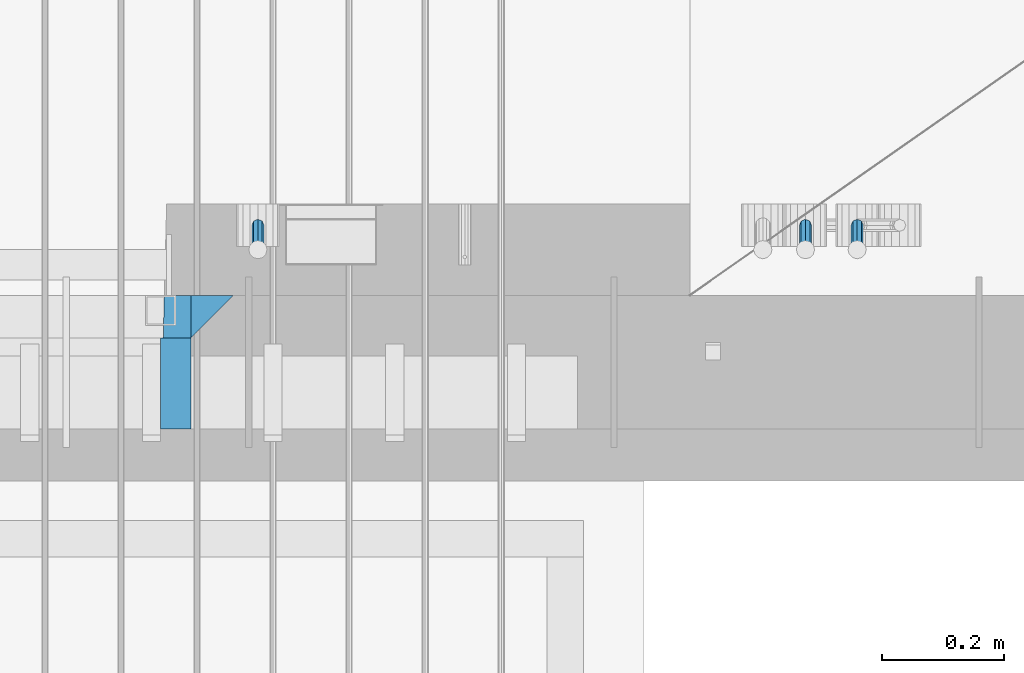
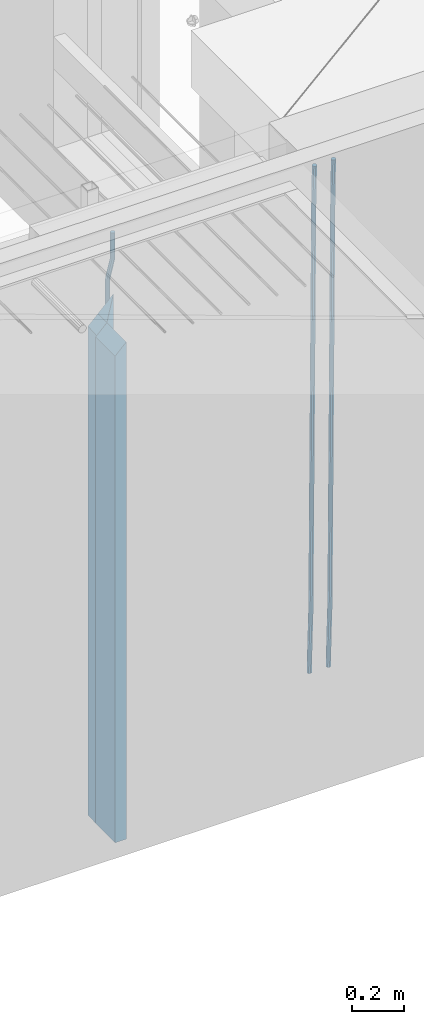
# One storey, part 130 of 350: 6 beams, 1 element without a shape of its own.
"""IFC2X3 building model written with IfcOpenShell, lengths in millimetres."""

from ifc_helpers import new_model, si_unit, frame, origin_with_axes, place, context, subcontext, project, spatial, faceted_brep, material, type_object, element, aggregate, save


model = new_model("IFC2X3")

# Units and contexts
model_context = context("Model", 3, precision=1e-05, world=origin_with_axes())
body_context = subcontext(model_context, "Body", "Model", "MODEL_VIEW")
ifc_project = project(units=[si_unit("LENGTHUNIT", "METRE", prefix="MILLI"), si_unit("AREAUNIT", "SQUARE_METRE"), si_unit("VOLUMEUNIT", "CUBIC_METRE"), si_unit("MASSUNIT", "GRAM", prefix="KILO"), si_unit("TIMEUNIT", "SECOND"), si_unit("PLANEANGLEUNIT", "RADIAN"), si_unit("SOLIDANGLEUNIT", "STERADIAN"), si_unit("THERMODYNAMICTEMPERATUREUNIT", "DEGREE_CELSIUS"), si_unit("LUMINOUSINTENSITYUNIT", "LUMEN")], contexts=[model_context])

# Site, building, storey
site_placement = place(None, origin_with_axes())
site = spatial("IfcSite", under=ifc_project, at=site_placement, CompositionType="ELEMENT")
building_placement = place(site_placement, origin_with_axes())
building = spatial("IfcBuilding", under=site, at=building_placement, CompositionType="ELEMENT")
storey_placement = place(building_placement, origin_with_axes())
storey = spatial("IfcBuildingStorey", under=building, at=storey_placement, Name="2", CompositionType="ELEMENT", Elevation=0.0)

# Assembly, beams
assembly_placement = place(storey_placement, origin_with_axes())
assembly = element("IfcElementAssembly", 1, at=assembly_placement, inside=storey, AssemblyPlace="NOTDEFINED", PredefinedType="REINFORCEMENT_UNIT")
ifc_material_1 = material(Name="CONCRETE/C35/45")
beam_type_1 = type_object("IfcBeamType", PredefinedType="NOTDEFINED")
beam_1_placement = place(assembly_placement, frame((33199.9988923323, 7815.0, 87175.0), z_axis=(-1.0, 3.00000001838171e-08, 0.0), x_axis=(0.0, 0.0, -1.0)))
beam_1 = element("IfcBeam", 2, at=beam_1_placement, type_object=beam_type_1, material=ifc_material_1, Name="SK", context=body_context, shape_type="Brep", body=[
    faceted_brep([(2420.0, -35.0, 35.0), (2420.0, -35.0, -35.0), (2420.0, 35.0, 35.0), (0.0, -35.0, -35.0), (70.0000000000164, 35.0, 35.0), (70.0000000000164, -35.0, 35.0)], [[[0, 1, 2]], [[2, 1, 3, 4]], [[0, 2, 4, 5]], [[1, 0, 5, 3]], [[5, 4, 3]]]),
])
beam_type_2 = type_object("IfcBeamType", PredefinedType="NOTDEFINED")
beam_2_placement = place(assembly_placement, frame((33139.9988923323, 7815.0, 87105.0), z_axis=(-1.0, 3.00000001838171e-08, 0.0), x_axis=(0.0, 0.0, -1.0)))
beam_2 = element("IfcBeam", 3, at=beam_2_placement, type_object=beam_type_2, material=ifc_material_1, Name="SK", context=body_context, shape_type="Brep", body=[
    faceted_brep([(2350.0, -35.0, -25.0), (2350.0, 35.0, -25.0), (2350.0, 35.0, 20.6410256410309), (2350.0, -35.0, 18.8461538461561), (0.0, -35.0, -25.0), (0.0, 35.0, -25.0), (45.6410256410309, 35.0, 20.6410256410254), (43.8461538461561, -35.0, 18.8461538461543)], [[[0, 1, 2, 3]], [[1, 0, 4, 5]], [[2, 1, 5, 6]], [[3, 2, 6, 7]], [[0, 3, 7, 4]], [[6, 5, 4, 7]]]),
])
ifc_material_2 = material(Name="TIMBER")
beam_type_3 = type_object("IfcBeamType", Name="50X150", PredefinedType="NOTDEFINED")
beam_3_placement = place(assembly_placement, frame((33139.9988923323, 7705.0, 87105.0), z_axis=(-1.0, 3.00000001838171e-08, 0.0), x_axis=(0.0, 0.0, -1.0)))
beam_3 = element("IfcBeam", 4, at=beam_3_placement, type_object=beam_type_3, material=ifc_material_2, ObjectType="50X150", context=body_context, shape_type="Brep", body=[
    faceted_brep([(2345.0, -75.0, 25.0), (2345.0, -75.0, -25.0), (2345.0, 75.0, -25.0), (2345.0, 75.0, 25.0), (0.0, -75.0, -25.0), (0.0, 75.0, -25.0), (50.0000000000036, 75.0, 25.0), (50.0000000000036, -75.0, 25.0)], [[[0, 1, 2, 3]], [[4, 5, 2, 1]], [[3, 2, 5, 6]], [[0, 3, 6, 7]], [[1, 0, 7, 4]], [[7, 6, 5, 4]]]),
])
ifc_material_3 = material()
beam_type_4 = type_object("IfcBeamType", Name="D20", PredefinedType="NOTDEFINED")
beam_4_placement = place(assembly_placement, frame((33274.9999999916, 7925.0, 87407.5), z_axis=(0.000415599999849905, 0.999999913638203, 4.76000000899737e-07), x_axis=(0.0, 0.0, -1.0)))
beam_4 = element("IfcBeam", 5, at=beam_4_placement, type_object=beam_type_4, material=ifc_material_3, Name="JM20", ObjectType="D20", context=body_context, shape_type="Brep", body=[
    faceted_brep([(0.0, -10.0, 0.0), (-4.19531716033816e-08, -7.07106781186667, -7.07106781187031), (113.248091332178, -7.0710684840451, -7.0710678117357), (113.248091314759, -10.0000006713562, -2.51020537689328e-10), (0.0, 0.0, -10.0), (113.248091374131, -6.72178430249915e-07, -9.99999999986903), (4.196772351861e-08, 7.07106781186303, -7.07106781186667), (113.248091416113, 7.07106713968824, -7.07106781173934), (0.0, 10.0, 0.0), (113.248091433488, 9.99999932782521, 1.30967237055302e-10), (4.196772351861e-08, 7.07106781185939, 7.07106781185939), (113.248091416113, 7.0710671396846, 7.071067811994), (0.0, 0.0, 10.0), (113.248091374131, -6.72174792271107e-07, 10.0000000001273), (-4.19531716033816e-08, -7.07106781187031, 7.07106781185939), (113.248091332178, -7.0710684840451, 7.071067811994), (130.699843527167, -7.06993249763036, -4.33745683788584), (128.538066582521, -9.99900540317321, 2.39499413731755), (131.594536475241, 0.00119355250353692, -7.12624594330919), (130.698046432328, 7.07220300913468, -4.33773834422391), (128.535525107087, 10.0009944322555, 2.39459602660281), (126.373748162892, 7.07192152754578, 9.1270470011732), (125.479055214906, 0.000795477419160306, 11.9158361066184), (126.37554525779, -7.07021397921199, 9.12732850753673), (240.336258550378, -7.05529970173666, 30.8729495437874), (238.174481606227, -9.98437260450009, 37.6054005176375), (241.230951498423, 0.0158263482953771, 28.0841604381058), (240.334461455612, 7.0868358050102, 30.8726680369582), (238.171940130502, 10.0156272283348, 37.6050024077231), (236.010163186409, 7.08655432384694, 44.3374533824244), (235.115470238379, 0.0154282738185429, 47.1262424881097), (236.011960281176, -7.05558118289991, 44.3377348892536), (253.461915329972, -7.05444528127919, 32.9289287376414), (253.46191532613, -9.98337746617108, 39.9999965521893), (253.461915339081, 0.0166225284556276, 29.9999965443676), (253.461915348205, 7.08769034247234, 32.9289287273205), (253.461915352003, 10.0166225357716, 39.9999965370152), (253.461915348293, 7.08769035281148, 47.0710643509774), (253.461915339183, 0.0166225430875784, 49.999996544273), (253.46191533003, -7.05444527093641, 47.0710643613093), (2417.50000002384, -7.0544364694706, 32.9289287374122), (2417.5000000337, -9.98336865393321, 39.9999965507959), (2417.49999999997, 0.0166313408753922, 29.9999965456082), (2417.49999997609, 7.08769915426274, 32.9289287300708), (2417.4999999662, 10.0166313460668, 39.9999965404204), (2417.49999997608, 7.08769916160054, 47.0710643538114), (2417.49999999994, 0.0166313512581837, 49.9999965456154), (2417.50000002382, -7.05443646212916, 47.0710643611455)], [[[0, 1, 2, 3]], [[1, 4, 5, 2]], [[4, 6, 7, 5]], [[6, 8, 9, 7]], [[8, 10, 11, 9]], [[10, 12, 13, 11]], [[12, 14, 15, 13]], [[14, 0, 3, 15]], [[14, 12, 10, 8, 6, 4, 1, 0]], [[3, 2, 16, 17]], [[2, 5, 18, 16]], [[5, 7, 19, 18]], [[7, 9, 20, 19]], [[9, 11, 21, 20]], [[11, 13, 22, 21]], [[13, 15, 23, 22]], [[15, 3, 17, 23]], [[17, 16, 24, 25]], [[16, 18, 26, 24]], [[18, 19, 27, 26]], [[19, 20, 28, 27]], [[20, 21, 29, 28]], [[21, 22, 30, 29]], [[22, 23, 31, 30]], [[23, 17, 25, 31]], [[25, 24, 32, 33]], [[24, 26, 34, 32]], [[26, 27, 35, 34]], [[27, 28, 36, 35]], [[28, 29, 37, 36]], [[29, 30, 38, 37]], [[30, 31, 39, 38]], [[31, 25, 33, 39]], [[33, 32, 40, 41]], [[32, 34, 42, 40]], [[34, 35, 43, 42]], [[35, 36, 44, 43]], [[36, 37, 45, 44]], [[37, 38, 46, 45]], [[38, 39, 47, 46]], [[39, 33, 41, 47]], [[42, 43, 44, 45, 46, 47, 41, 40]]]),
])
beam_5_placement = place(assembly_placement, frame((34259.9999999961, 7965.00000227913, 84990.0), z_axis=(0.00020576299992186, -0.999642804629538, -0.0267249099901004), x_axis=(-4.30000201928125e-08, -0.0267249099948059, 0.999642825806181)))
beam_5 = element("IfcBeam", 6, at=beam_5_placement, type_object=beam_type_4, material=ifc_material_3, Name="JM20", ObjectType="D20", context=body_context, shape_type="Brep", body=[
    faceted_brep([(0.0, -10.0, 0.0), (-4.19531716033816e-08, -7.07106781186667, -7.07106781187031), (60.4266690400545, -7.0710677960451, -7.07106780570757), (60.4266690441291, -9.99999998418934, 6.15546014159918e-09), (0.0, 0.0, -10.0), (60.426669036824, 1.58106558956206e-08, -9.99999999384454), (4.196772351861e-08, 7.07106781186303, -7.07106781186667), (60.4266690363438, 7.07106782768096, -7.07106780570757), (0.0, 10.0, 0.0), (60.4266690388904, 10.0000000158179, 6.15182216279209e-09), (4.196772351861e-08, 7.07106781185939, 7.07106781185939), (60.4266690429649, 7.07106782768096, 7.07106781802577), (0.0, 0.0, 10.0), (60.4266690461809, 1.58179318532348e-08, 10.0000000061555), (-4.19531716033816e-08, -7.07106781187031, 7.07106781185939), (60.4266690466611, -7.07106779605238, 7.07106781802213), (61.0378400410118, -7.07106779588503, -7.07106780564936), (60.991799419251, -9.99999998403655, 6.21366780251265e-09), (61.0569027789461, 1.5985278878361e-08, -9.99999999378269), (61.0378209396877, 7.07106782784831, -7.07106780564936), (60.9917724058905, 10.0000000159635, 6.21366780251265e-09), (60.9457317841297, 7.07106782781193, 7.0710678180767), (60.9266690461809, 1.59488990902901e-08, 10.0000000062028), (60.9457508854539, -7.07106779591413, 7.0710678180767), (61.6489592143771, -7.07106614513759, -7.06310863441468), (61.5568818710308, -9.9999984576425, 0.00735959856683621), (61.6870830769039, 1.71821739058942e-06, -9.99179257185824), (61.6489210170112, 7.07106947854481, -7.06310888312146), (61.556827851804, 10.0000015422847, 0.00735924683976918), (61.4647505084577, 7.07106922979438, 7.07782747982128), (61.4266266459163, 1.36643211590126e-06, 10.0065114172685), (61.464788705809, -7.07106639389531, 7.07782772852806), (176.543135720174, -7.07075579406956, -5.56673531796696), (176.451058376813, -9.99968810657447, 1.50373291501455), (176.581259582701, 0.000312069292704109, -8.49541925541052), (176.543097522794, 7.07137982961285, -5.56673556667374), (176.451004357587, 10.00031189336, 1.50373256329476), (176.35892701424, 7.07137958085514, 8.57420079627263), (176.320803151699, 0.000311717507429421, 11.5028847337162), (176.358965211621, -7.07075604281999, 8.57420104497578), (177.098753836006, -7.07075429323595, -5.55949898843028), (176.98362511232, -9.99968666800123, 1.510669025065), (177.146421932586, 0.000313595905026887, -8.48805862247536), (177.098706077581, 7.07138133041735, -5.55949936166144), (176.983557571715, 10.0003133318824, 1.51066849724157), (176.868428848029, 7.07138095712435, 8.58083651073321), (176.820760751449, 0.000313067976094317, 11.5093961447819), (176.868476606425, -7.07075466652896, 8.58083688396073), (177.654312950661, -7.07075204110879, -5.54863964998367), (177.516135294456, -9.99968450931192, 1.52107783331303), (177.711524267797, 0.000315886711177882, -8.47701274570863), (177.654255632195, 7.07138358250813, -5.54864021007961), (177.516054233929, 10.0003154905207, 1.5210770412159), (177.377876577739, 7.0713830223176, 8.59079452451624), (177.320665260588, 0.000315094497636892, 11.5191676202448), (177.377933896176, -7.07075260129932, 8.59079508461218), (299.436796249574, -7.07025836271714, -3.1681962331204), (299.298618593355, -9.99919083092027, 3.90152125031091), (299.494007566798, 0.000809565110102994, -6.09656932889993), (299.436738931283, 7.07187726089978, -3.16819679320906), (299.298537533061, 10.0008091689197, 3.90152045822106), (299.160359876842, 7.07187670072017, 10.9712379416487), (299.103148559603, 0.000808772889286047, 13.8996110374392), (299.160417195119, -7.07025892290039, 10.9712385017483), (299.98743051647, -7.07025613056248, -3.15743315966392), (299.971788958996, -9.99918809853989, 3.91467979818117), (299.993912075952, 0.000811591617093654, -6.08679785393178), (299.987423933868, 7.07187949325817, -3.1574327280432), (299.971753863239, 10.0008119014747, 3.91467990454839), (299.95611230444, 7.07187992653053, 10.9867922621015), (299.949630744944, 0.000812204350950196, 13.9161569563694), (299.956118887014, -7.07025569729012, 10.9867918304735), (300.538107039494, -7.07025785017686, -3.16575821840888), (300.644985195438, -9.99919020432935, 3.90450175465594), (300.493854948218, 0.000810030429420294, -6.09435592770024), (300.538151196495, 7.071877773491, -3.16575855385963), (300.645047642858, 10.0008097955724, 3.90450128024895), (300.751925798773, 7.07187744142357, 10.9747612533101), (300.796177890064, 0.000809560813650023, 13.9033589625978), (300.751881641787, -7.07025818224065, 10.9747615887682), (2293.36490490142, -7.07648090940347, -33.2930642912361), (2293.47178305736, -10.0054132635523, -26.2228043181785), (2293.32065281013, -0.00541302880083094, -36.2216620005347), (2293.36494905842, 7.06565471425711, -33.2930646266868), (2293.47184550477, 9.99458673634581, -26.2228047925819), (2293.57872366071, 7.06565438219332, -19.1525448195243), (2293.62297575199, -0.00541349841296324, -16.2239471102366), (2293.57867950371, -7.0764812414709, -19.1525444840736), (2294.0658245362, -7.07648309818615, -33.3036607065333), (2294.05312277409, -10.0054150789219, -26.2315929392535), (2294.10928714235, -0.00541549149056664, -36.2335844756526), (2294.15805078732, 7.06565223761572, -33.3050546393533), (2294.18355038921, 9.99458451388637, -26.2335642579346), (2294.17084862708, 7.06565253314329, -19.1614964906439), (2294.12738602093, -0.00541507354500936, -16.2315727215355), (2294.07862237596, -7.07648280265857, -19.1601025578348), (2294.76670261032, -7.08562269121467, -33.294332712383), (2294.63442802057, -10.0129954178956, -26.2238563411993), (2294.89787471293, -0.0156988342423574, -36.2230891548279), (2294.95110548967, 7.05531064255774, -33.2944998654275), (2294.89521307347, 9.98530428734011, -26.2240927312887), (2294.76293848372, 7.0579315606592, -19.1536163601049), (2294.63176638114, -0.0119922963167483, -16.2248599176673), (2294.57853560438, -7.08300177311321, -19.1534492070678), (2316.52657204497, -7.36937582653991, -33.0047303660212), (2316.39429745522, -10.2967485532172, -25.9342539948302), (2316.65774414754, -0.299451969567599, -35.9334868084661), (2316.7109749243, 6.7715575072325, -33.0048975190657), (2316.65508250811, 9.70155115201487, -25.9344903849269), (2316.52280791836, 6.7741784253376, -18.8640140137468), (2316.39163581574, -0.295745431634714, -15.9352575713092), (2316.33840503903, -7.36675490843481, -18.863846860706), (2317.16202064224, -7.37766220584308, -32.9962731735213), (2317.05438744847, -10.3053562613532, -25.9254688497131), (2317.23607125619, -0.306993473008333, -35.925789846493), (2317.23316144495, 6.76474808850253, -32.9979477328052), (2317.15499573652, 9.6950321815566, -25.9278370341635), (2317.04736254275, 6.7673381260538, -18.8570327103698), (2316.97331192881, -0.303330606784584, -15.9275160373909), (2316.97622174003, -7.37507216829545, -18.8553581510787), (2317.79752306276, -7.37578610372293, -32.9880110666527), (2317.71453320107, -10.3033876998124, -25.9168792378296), (2317.81444760226, -0.305295583297266, -35.918287695793), (2317.75539265381, 6.76628640723357, -32.9911928173897), (2317.65495180529, 9.69652304524061, -25.9213789128698), (2317.5719619436, 6.76892144914746, -18.8502470840467), (2317.55503740412, -0.301569071270933, -15.9199704549137), (2317.61409235255, -7.3731510618054, -18.847065333317), (2417.8183084176, -7.07752398473531, -31.6906369377139), (2417.73531855589, -10.0051255808248, -24.6195051088798), (2417.83523295709, -0.007033464313281, -34.6209135668432), (2417.77617800863, 7.06454852621755, -31.6938186884508), (2417.67573716014, 9.99478516423187, -24.6240047839383), (2417.59274729842, 7.06718356813872, -17.5528729551006), (2417.57582275895, -0.00330695228694822, -14.6225963259749), (2417.6348777074, -7.07488894281778, -17.5496912043673)], [[[0, 1, 2, 3]], [[1, 4, 5, 2]], [[4, 6, 7, 5]], [[6, 8, 9, 7]], [[8, 10, 11, 9]], [[10, 12, 13, 11]], [[12, 14, 15, 13]], [[14, 0, 3, 15]], [[14, 12, 10, 8, 6, 4, 1, 0]], [[3, 2, 16, 17]], [[2, 5, 18, 16]], [[5, 7, 19, 18]], [[7, 9, 20, 19]], [[9, 11, 21, 20]], [[11, 13, 22, 21]], [[13, 15, 23, 22]], [[15, 3, 17, 23]], [[17, 16, 24, 25]], [[16, 18, 26, 24]], [[18, 19, 27, 26]], [[19, 20, 28, 27]], [[20, 21, 29, 28]], [[21, 22, 30, 29]], [[22, 23, 31, 30]], [[23, 17, 25, 31]], [[25, 24, 32, 33]], [[24, 26, 34, 32]], [[26, 27, 35, 34]], [[27, 28, 36, 35]], [[28, 29, 37, 36]], [[29, 30, 38, 37]], [[30, 31, 39, 38]], [[31, 25, 33, 39]], [[33, 32, 40, 41]], [[32, 34, 42, 40]], [[34, 35, 43, 42]], [[35, 36, 44, 43]], [[36, 37, 45, 44]], [[37, 38, 46, 45]], [[38, 39, 47, 46]], [[39, 33, 41, 47]], [[41, 40, 48, 49]], [[40, 42, 50, 48]], [[42, 43, 51, 50]], [[43, 44, 52, 51]], [[44, 45, 53, 52]], [[45, 46, 54, 53]], [[46, 47, 55, 54]], [[47, 41, 49, 55]], [[49, 48, 56, 57]], [[48, 50, 58, 56]], [[50, 51, 59, 58]], [[51, 52, 60, 59]], [[52, 53, 61, 60]], [[53, 54, 62, 61]], [[54, 55, 63, 62]], [[55, 49, 57, 63]], [[57, 56, 64, 65]], [[56, 58, 66, 64]], [[58, 59, 67, 66]], [[59, 60, 68, 67]], [[60, 61, 69, 68]], [[61, 62, 70, 69]], [[62, 63, 71, 70]], [[63, 57, 65, 71]], [[65, 64, 72, 73]], [[64, 66, 74, 72]], [[66, 67, 75, 74]], [[67, 68, 76, 75]], [[68, 69, 77, 76]], [[69, 70, 78, 77]], [[70, 71, 79, 78]], [[71, 65, 73, 79]], [[73, 72, 80, 81]], [[72, 74, 82, 80]], [[74, 75, 83, 82]], [[75, 76, 84, 83]], [[76, 77, 85, 84]], [[77, 78, 86, 85]], [[78, 79, 87, 86]], [[79, 73, 81, 87]], [[81, 80, 88, 89]], [[80, 82, 90, 88]], [[82, 83, 91, 90]], [[83, 84, 92, 91]], [[84, 85, 93, 92]], [[85, 86, 94, 93]], [[86, 87, 95, 94]], [[87, 81, 89, 95]], [[89, 88, 96, 97]], [[88, 90, 98, 96]], [[90, 91, 99, 98]], [[91, 92, 100, 99]], [[92, 93, 101, 100]], [[93, 94, 102, 101]], [[94, 95, 103, 102]], [[95, 89, 97, 103]], [[97, 96, 104, 105]], [[96, 98, 106, 104]], [[98, 99, 107, 106]], [[99, 100, 108, 107]], [[100, 101, 109, 108]], [[101, 102, 110, 109]], [[102, 103, 111, 110]], [[103, 97, 105, 111]], [[105, 104, 112, 113]], [[104, 106, 114, 112]], [[106, 107, 115, 114]], [[107, 108, 116, 115]], [[108, 109, 117, 116]], [[109, 110, 118, 117]], [[110, 111, 119, 118]], [[111, 105, 113, 119]], [[113, 112, 120, 121]], [[112, 114, 122, 120]], [[114, 115, 123, 122]], [[115, 116, 124, 123]], [[116, 117, 125, 124]], [[117, 118, 126, 125]], [[118, 119, 127, 126]], [[119, 113, 121, 127]], [[121, 120, 128, 129]], [[120, 122, 130, 128]], [[122, 123, 131, 130]], [[123, 124, 132, 131]], [[124, 125, 133, 132]], [[125, 126, 134, 133]], [[126, 127, 135, 134]], [[127, 121, 129, 135]], [[130, 131, 132, 133, 134, 135, 129, 128]]]),
])
beam_6_placement = place(assembly_placement, frame((34174.9999999961, 7965.00000227913, 84990.0), z_axis=(0.00020576299992186, -0.999642804629538, -0.0267249099901004), x_axis=(-4.30000201928125e-08, -0.0267249099948059, 0.999642825806181)))
beam_6 = element("IfcBeam", 7, at=beam_6_placement, type_object=beam_type_4, material=ifc_material_3, Name="JM20", ObjectType="D20", context=body_context, shape_type="Brep", body=[
    faceted_brep([(0.0, -10.0, 0.0), (-4.19531716033816e-08, -7.07106781186667, -7.07106781187031), (60.4266690400545, -7.0710677960451, -7.07106780570757), (60.4266690441291, -9.99999998418934, 6.15546014159918e-09), (0.0, 0.0, -10.0), (60.426669036824, 1.58106558956206e-08, -9.99999999384454), (4.196772351861e-08, 7.07106781186303, -7.07106781186667), (60.4266690363438, 7.07106782768096, -7.07106780570757), (0.0, 10.0, 0.0), (60.4266690388904, 10.0000000158179, 6.15182216279209e-09), (4.196772351861e-08, 7.07106781185939, 7.07106781185939), (60.4266690429649, 7.07106782768096, 7.07106781802577), (0.0, 0.0, 10.0), (60.4266690461809, 1.58179318532348e-08, 10.0000000061555), (-4.19531716033816e-08, -7.07106781187031, 7.07106781185939), (60.4266690466611, -7.07106779605238, 7.07106781802213), (61.0378400410118, -7.07106779588503, -7.07106780564936), (60.991799419251, -9.99999998403655, 6.21366780251265e-09), (61.0569027789461, 1.5985278878361e-08, -9.99999999378269), (61.0378209396877, 7.07106782784831, -7.07106780564936), (60.9917724058905, 10.0000000159635, 6.21366780251265e-09), (60.9457317841297, 7.07106782781193, 7.0710678180767), (60.9266690461809, 1.59488990902901e-08, 10.0000000062028), (60.9457508854539, -7.07106779591413, 7.0710678180767), (61.6489592143771, -7.07106614513759, -7.06310863441468), (61.5568818710308, -9.9999984576425, 0.00735959856683621), (61.6870830769039, 1.71821739058942e-06, -9.99179257185824), (61.6489210170112, 7.07106947854481, -7.06310888312146), (61.556827851804, 10.0000015422847, 0.00735924683976918), (61.4647505084577, 7.07106922979438, 7.07782747982128), (61.4266266459163, 1.36643211590126e-06, 10.0065114172685), (61.464788705809, -7.07106639389531, 7.07782772852806), (176.543135720174, -7.07075579406956, -5.56673531796696), (176.451058376813, -9.99968810657447, 1.50373291501455), (176.581259582701, 0.000312069292704109, -8.49541925541052), (176.543097522794, 7.07137982961285, -5.56673556667374), (176.451004357587, 10.00031189336, 1.50373256329476), (176.35892701424, 7.07137958085514, 8.57420079627263), (176.320803151699, 0.000311717507429421, 11.5028847337162), (176.358965211621, -7.07075604281999, 8.57420104497578), (177.098753836006, -7.07075429323595, -5.55949898843028), (176.98362511232, -9.99968666800123, 1.510669025065), (177.146421932586, 0.000313595905026887, -8.48805862247536), (177.098706077581, 7.07138133041735, -5.55949936166144), (176.983557571715, 10.0003133318824, 1.51066849724157), (176.868428848029, 7.07138095712435, 8.58083651073321), (176.820760751449, 0.000313067976094317, 11.5093961447819), (176.868476606425, -7.07075466652896, 8.58083688396073), (177.654312950661, -7.07075204110879, -5.54863964998367), (177.516135294456, -9.99968450931192, 1.52107783331303), (177.711524267797, 0.000315886711177882, -8.47701274570863), (177.654255632195, 7.07138358250813, -5.54864021007961), (177.516054233929, 10.0003154905207, 1.5210770412159), (177.377876577739, 7.0713830223176, 8.59079452451624), (177.320665260588, 0.000315094497636892, 11.5191676202448), (177.377933896176, -7.07075260129932, 8.59079508461218), (299.436796249574, -7.07025836271714, -3.1681962331204), (299.298618593355, -9.99919083092027, 3.90152125031091), (299.494007566798, 0.000809565110102994, -6.09656932889993), (299.436738931283, 7.07187726089978, -3.16819679320906), (299.298537533061, 10.0008091689197, 3.90152045822106), (299.160359876842, 7.07187670072017, 10.9712379416487), (299.103148559603, 0.000808772889286047, 13.8996110374392), (299.160417195119, -7.07025892290039, 10.9712385017483), (299.98743051647, -7.07025613056248, -3.15743315966392), (299.971788958996, -9.99918809853989, 3.91467979818117), (299.993912075952, 0.000811591617093654, -6.08679785393178), (299.987423933868, 7.07187949325817, -3.1574327280432), (299.971753863239, 10.0008119014747, 3.91467990454839), (299.95611230444, 7.07187992653053, 10.9867922621015), (299.949630744944, 0.000812204350950196, 13.9161569563694), (299.956118887014, -7.07025569729012, 10.9867918304735), (300.538107039494, -7.07025785017686, -3.16575821840888), (300.644985195438, -9.99919020432935, 3.90450175465594), (300.493854948218, 0.000810030429420294, -6.09435592770024), (300.538151196495, 7.071877773491, -3.16575855385963), (300.645047642858, 10.0008097955724, 3.90450128024895), (300.751925798773, 7.07187744142357, 10.9747612533101), (300.796177890064, 0.000809560813650023, 13.9033589625978), (300.751881641787, -7.07025818224065, 10.9747615887682), (2293.36490490142, -7.07648090940347, -33.2930642912361), (2293.47178305736, -10.0054132635523, -26.2228043181785), (2293.32065281013, -0.00541302880083094, -36.2216620005347), (2293.36494905842, 7.06565471425711, -33.2930646266868), (2293.47184550477, 9.99458673634581, -26.2228047925819), (2293.57872366071, 7.06565438219332, -19.1525448195243), (2293.62297575199, -0.00541349841296324, -16.2239471102366), (2293.57867950371, -7.0764812414709, -19.1525444840736), (2294.0658245362, -7.07648309818615, -33.3036607065333), (2294.05312277409, -10.0054150789219, -26.2315929392535), (2294.10928714235, -0.00541549149056664, -36.2335844756526), (2294.15805078732, 7.06565223761572, -33.3050546393533), (2294.18355038921, 9.99458451388637, -26.2335642579346), (2294.17084862708, 7.06565253314329, -19.1614964906439), (2294.12738602093, -0.00541507354500936, -16.2315727215355), (2294.07862237596, -7.07648280265857, -19.1601025578348), (2294.76670261032, -7.08562269121467, -33.294332712383), (2294.63442802057, -10.0129954178956, -26.2238563411993), (2294.89787471293, -0.0156988342423574, -36.2230891548279), (2294.95110548967, 7.05531064255774, -33.2944998654275), (2294.89521307347, 9.98530428734011, -26.2240927312887), (2294.76293848372, 7.0579315606592, -19.1536163601049), (2294.63176638114, -0.0119922963167483, -16.2248599176673), (2294.57853560438, -7.08300177311321, -19.1534492070678), (2316.52657204497, -7.36937582653991, -33.0047303660212), (2316.39429745522, -10.2967485532172, -25.9342539948302), (2316.65774414754, -0.299451969567599, -35.9334868084661), (2316.7109749243, 6.7715575072325, -33.0048975190657), (2316.65508250811, 9.70155115201487, -25.9344903849269), (2316.52280791836, 6.7741784253376, -18.8640140137468), (2316.39163581574, -0.295745431634714, -15.9352575713092), (2316.33840503903, -7.36675490843481, -18.863846860706), (2317.16202064224, -7.37766220584308, -32.9962731735213), (2317.05438744847, -10.3053562613532, -25.9254688497131), (2317.23607125619, -0.306993473008333, -35.925789846493), (2317.23316144495, 6.76474808850253, -32.9979477328052), (2317.15499573652, 9.6950321815566, -25.9278370341635), (2317.04736254275, 6.7673381260538, -18.8570327103698), (2316.97331192881, -0.303330606784584, -15.9275160373909), (2316.97622174003, -7.37507216829545, -18.8553581510787), (2317.79752306276, -7.37578610372293, -32.9880110666527), (2317.71453320107, -10.3033876998124, -25.9168792378296), (2317.81444760226, -0.305295583297266, -35.918287695793), (2317.75539265381, 6.76628640723357, -32.9911928173897), (2317.65495180529, 9.69652304524061, -25.9213789128698), (2317.5719619436, 6.76892144914746, -18.8502470840467), (2317.55503740412, -0.301569071270933, -15.9199704549137), (2317.61409235255, -7.3731510618054, -18.847065333317), (2417.8183084176, -7.07752398473531, -31.6906369377139), (2417.73531855589, -10.0051255808248, -24.6195051088798), (2417.83523295709, -0.007033464313281, -34.6209135668432), (2417.77617800863, 7.06454852621755, -31.6938186884508), (2417.67573716014, 9.99478516423187, -24.6240047839383), (2417.59274729842, 7.06718356813872, -17.5528729551006), (2417.57582275895, -0.00330695228694822, -14.6225963259749), (2417.6348777074, -7.07488894281778, -17.5496912043673)], [[[0, 1, 2, 3]], [[1, 4, 5, 2]], [[4, 6, 7, 5]], [[6, 8, 9, 7]], [[8, 10, 11, 9]], [[10, 12, 13, 11]], [[12, 14, 15, 13]], [[14, 0, 3, 15]], [[14, 12, 10, 8, 6, 4, 1, 0]], [[3, 2, 16, 17]], [[2, 5, 18, 16]], [[5, 7, 19, 18]], [[7, 9, 20, 19]], [[9, 11, 21, 20]], [[11, 13, 22, 21]], [[13, 15, 23, 22]], [[15, 3, 17, 23]], [[17, 16, 24, 25]], [[16, 18, 26, 24]], [[18, 19, 27, 26]], [[19, 20, 28, 27]], [[20, 21, 29, 28]], [[21, 22, 30, 29]], [[22, 23, 31, 30]], [[23, 17, 25, 31]], [[25, 24, 32, 33]], [[24, 26, 34, 32]], [[26, 27, 35, 34]], [[27, 28, 36, 35]], [[28, 29, 37, 36]], [[29, 30, 38, 37]], [[30, 31, 39, 38]], [[31, 25, 33, 39]], [[33, 32, 40, 41]], [[32, 34, 42, 40]], [[34, 35, 43, 42]], [[35, 36, 44, 43]], [[36, 37, 45, 44]], [[37, 38, 46, 45]], [[38, 39, 47, 46]], [[39, 33, 41, 47]], [[41, 40, 48, 49]], [[40, 42, 50, 48]], [[42, 43, 51, 50]], [[43, 44, 52, 51]], [[44, 45, 53, 52]], [[45, 46, 54, 53]], [[46, 47, 55, 54]], [[47, 41, 49, 55]], [[49, 48, 56, 57]], [[48, 50, 58, 56]], [[50, 51, 59, 58]], [[51, 52, 60, 59]], [[52, 53, 61, 60]], [[53, 54, 62, 61]], [[54, 55, 63, 62]], [[55, 49, 57, 63]], [[57, 56, 64, 65]], [[56, 58, 66, 64]], [[58, 59, 67, 66]], [[59, 60, 68, 67]], [[60, 61, 69, 68]], [[61, 62, 70, 69]], [[62, 63, 71, 70]], [[63, 57, 65, 71]], [[65, 64, 72, 73]], [[64, 66, 74, 72]], [[66, 67, 75, 74]], [[67, 68, 76, 75]], [[68, 69, 77, 76]], [[69, 70, 78, 77]], [[70, 71, 79, 78]], [[71, 65, 73, 79]], [[73, 72, 80, 81]], [[72, 74, 82, 80]], [[74, 75, 83, 82]], [[75, 76, 84, 83]], [[76, 77, 85, 84]], [[77, 78, 86, 85]], [[78, 79, 87, 86]], [[79, 73, 81, 87]], [[81, 80, 88, 89]], [[80, 82, 90, 88]], [[82, 83, 91, 90]], [[83, 84, 92, 91]], [[84, 85, 93, 92]], [[85, 86, 94, 93]], [[86, 87, 95, 94]], [[87, 81, 89, 95]], [[89, 88, 96, 97]], [[88, 90, 98, 96]], [[90, 91, 99, 98]], [[91, 92, 100, 99]], [[92, 93, 101, 100]], [[93, 94, 102, 101]], [[94, 95, 103, 102]], [[95, 89, 97, 103]], [[97, 96, 104, 105]], [[96, 98, 106, 104]], [[98, 99, 107, 106]], [[99, 100, 108, 107]], [[100, 101, 109, 108]], [[101, 102, 110, 109]], [[102, 103, 111, 110]], [[103, 97, 105, 111]], [[105, 104, 112, 113]], [[104, 106, 114, 112]], [[106, 107, 115, 114]], [[107, 108, 116, 115]], [[108, 109, 117, 116]], [[109, 110, 118, 117]], [[110, 111, 119, 118]], [[111, 105, 113, 119]], [[113, 112, 120, 121]], [[112, 114, 122, 120]], [[114, 115, 123, 122]], [[115, 116, 124, 123]], [[116, 117, 125, 124]], [[117, 118, 126, 125]], [[118, 119, 127, 126]], [[119, 113, 121, 127]], [[121, 120, 128, 129]], [[120, 122, 130, 128]], [[122, 123, 131, 130]], [[123, 124, 132, 131]], [[124, 125, 133, 132]], [[125, 126, 134, 133]], [[126, 127, 135, 134]], [[127, 121, 129, 135]], [[130, 131, 132, 133, 134, 135, 129, 128]]]),
])
aggregate(assembly, [beam_4, beam_5, beam_6, beam_1, beam_2, beam_3])

save(model, "model.ifc")
